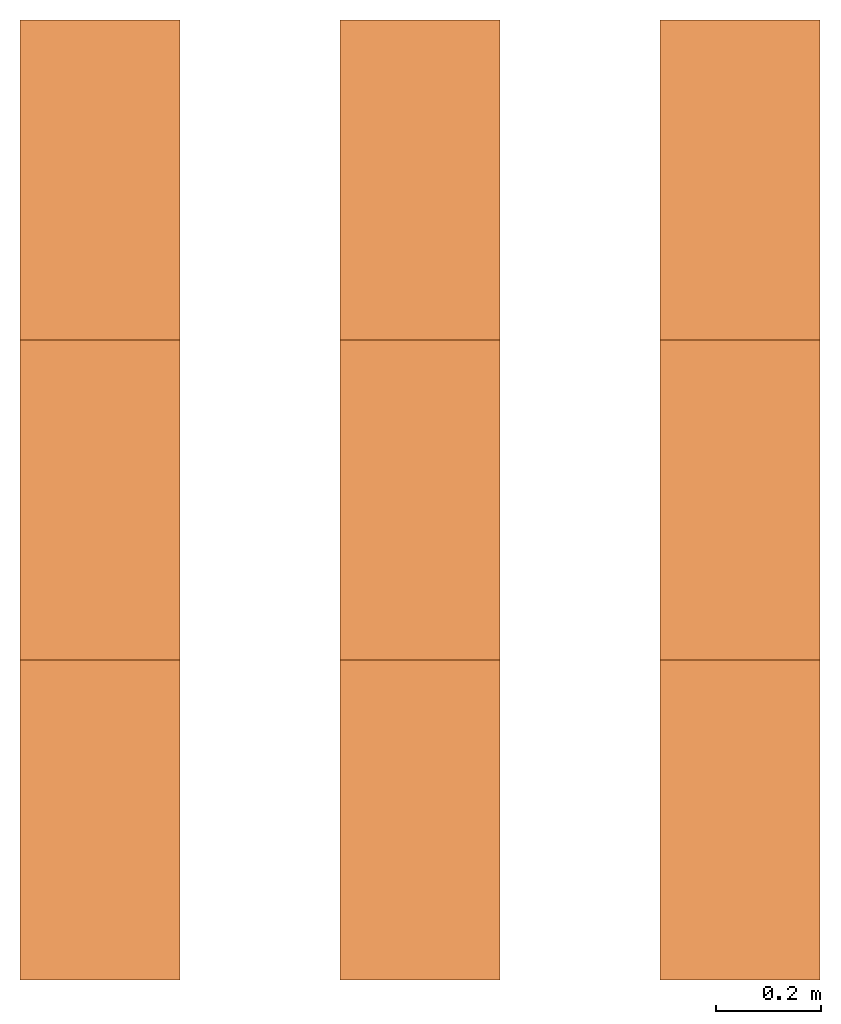
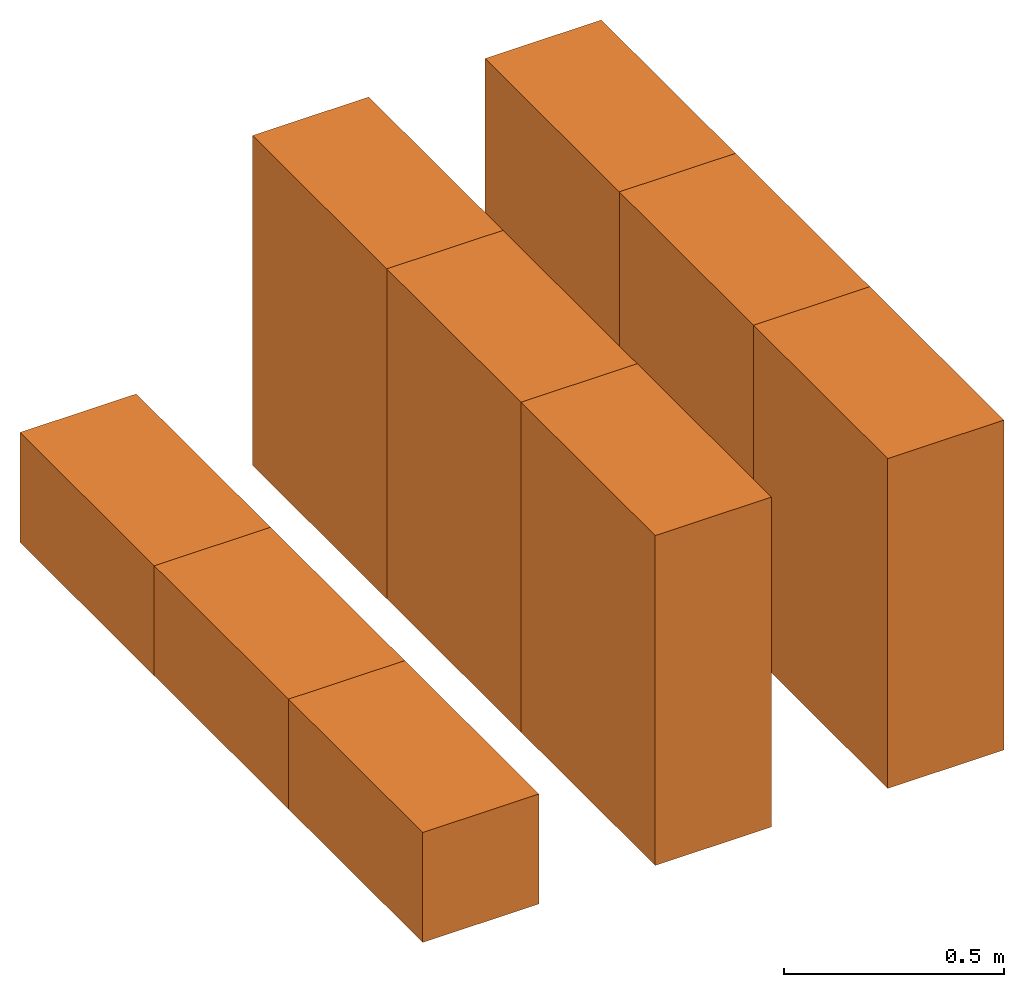
# One storey: 9 proxies.
"""IFC2X3 building model written with IfcOpenShell, lengths in feet."""

from ifc_helpers import new_model, entity, si_unit, converted_unit, derived_unit, direction, frame, frame_2d, origin, origin_2d_with_axis, place, context, subcontext, project, spatial, rectangle, extrude, source, transform, mapped, material, type_object, type_shapes, element, save


model = new_model("IFC2X3")

# Units and contexts
model_context = context("Model", 3, precision=0.0001, world=origin(), true_north=direction((6.12303176911189e-17, 1.0)))
body_context = subcontext(model_context, "Body", "Model", "MODEL_VIEW")
ifc_project = project(units=[converted_unit("LENGTHUNIT", "FOOT", entity("IfcRatioMeasure", 0.3048), si_unit("LENGTHUNIT", "METRE"), dimensions=[1, 0, 0, 0, 0, 0, 0]), converted_unit("AREAUNIT", "SQUARE FOOT", entity("IfcRatioMeasure", 0.09290304), si_unit("AREAUNIT", "SQUARE_METRE"), dimensions=[2, 0, 0, 0, 0, 0, 0]), converted_unit("VOLUMEUNIT", "CUBIC FOOT", entity("IfcRatioMeasure", 0.028316846592), si_unit("VOLUMEUNIT", "CUBIC_METRE"), dimensions=[3, 0, 0, 0, 0, 0, 0]), converted_unit("PLANEANGLEUNIT", "DEGREE", entity("IfcRatioMeasure", 0.0174532925199433), si_unit("PLANEANGLEUNIT", "RADIAN"), dimensions=[0, 0, 0, 0, 0, 0, 0]), si_unit("MASSUNIT", "GRAM", prefix="KILO"), derived_unit("MASSDENSITYUNIT", [(si_unit("MASSUNIT", "GRAM", prefix="KILO"), 1), (si_unit("LENGTHUNIT", "METRE"), -3)]), derived_unit("MOMENTOFINERTIAUNIT", [(si_unit("LENGTHUNIT", "METRE"), 4)]), si_unit("TIMEUNIT", "SECOND"), si_unit("FREQUENCYUNIT", "HERTZ"), si_unit("THERMODYNAMICTEMPERATUREUNIT", "DEGREE_CELSIUS"), derived_unit("THERMALTRANSMITTANCEUNIT", [(si_unit("MASSUNIT", "GRAM", prefix="KILO"), 1), (si_unit("THERMODYNAMICTEMPERATUREUNIT", "KELVIN"), -1), (si_unit("TIMEUNIT", "SECOND"), -3)]), derived_unit("VOLUMETRICFLOWRATEUNIT", [(si_unit("LENGTHUNIT", "METRE"), 3), (si_unit("TIMEUNIT", "SECOND"), -1)]), si_unit("ELECTRICCURRENTUNIT", "AMPERE"), si_unit("ELECTRICVOLTAGEUNIT", "VOLT"), si_unit("POWERUNIT", "WATT"), si_unit("FORCEUNIT", "NEWTON"), si_unit("ILLUMINANCEUNIT", "LUX"), si_unit("LUMINOUSFLUXUNIT", "LUMEN"), si_unit("LUMINOUSINTENSITYUNIT", "CANDELA"), derived_unit("USERDEFINED", [(si_unit("MASSUNIT", "GRAM", prefix="KILO"), -1), (si_unit("LENGTHUNIT", "METRE"), -2), (si_unit("TIMEUNIT", "SECOND"), 3), (si_unit("LUMINOUSFLUXUNIT", "LUMEN"), 1)]), derived_unit("LINEARVELOCITYUNIT", [(si_unit("LENGTHUNIT", "METRE"), 1), (si_unit("TIMEUNIT", "SECOND"), -1)]), si_unit("PRESSUREUNIT", "PASCAL"), derived_unit("USERDEFINED", [(si_unit("LENGTHUNIT", "METRE"), -2), (si_unit("MASSUNIT", "GRAM", prefix="KILO"), 1), (si_unit("TIMEUNIT", "SECOND"), -2)]), derived_unit("LINEARFORCEUNIT", [(si_unit("MASSUNIT", "GRAM", prefix="KILO"), 1), (si_unit("LENGTHUNIT", "METRE"), 1), (si_unit("TIMEUNIT", "SECOND"), -2), (si_unit("LENGTHUNIT", "METRE"), -1)]), derived_unit("PLANARFORCEUNIT", [(si_unit("MASSUNIT", "GRAM", prefix="KILO"), 1), (si_unit("LENGTHUNIT", "METRE"), 1), (si_unit("TIMEUNIT", "SECOND"), -2), (si_unit("LENGTHUNIT", "METRE"), -2)])], contexts=[model_context])

# Site, building, storey
site_placement = place(None, origin())
site = spatial("IfcSite", under=ifc_project, at=site_placement, CompositionType="ELEMENT")
building_placement = place(site_placement, origin())
building = spatial("IfcBuilding", under=site, at=building_placement, CompositionType="ELEMENT")
storey_placement = place(building_placement, origin())
storey = spatial("IfcBuildingStorey", under=building, at=storey_placement, Name="Level 1", CompositionType="ELEMENT", Elevation=0.0)

# Proxies
ifc_material = material()
building_element_proxy_type_1 = type_object("IfcBuildingElementProxyType", PredefinedType="NOTDEFINED", material=ifc_material)
shared_shape_1 = source(origin(), body_context, "Body", "SweptSolid", [
    extrude(rectangle(XDim=2.0, YDim=1.0, at=frame_2d((0.0, 1.11022302462516e-16), x_axis=(1.0, 0.0))), frame((0.500000000000003, 1.0, 0.0), z_axis=(0.0, 0.0, 1.0), x_axis=(0.0, 1.0, 0.0)), (0.0, 0.0, 1.0), 3.0),
])
type_shapes(building_element_proxy_type_1, [shared_shape_1])
proxy_1_placement = place(storey_placement, origin())
element("IfcBuildingElementProxy", 1, at=proxy_1_placement, inside=storey, type_object=building_element_proxy_type_1, material=ifc_material, context=body_context, shape_type="MappedRepresentation", body=[
    mapped(shared_shape_1, transform((0.0, 0.0, 0.0), scale=1.0)),
])
building_element_proxy_type_2 = type_object("IfcBuildingElementProxyType", Name="IPF1:IPF", PredefinedType="NOTDEFINED", material=ifc_material)
shared_shape_2 = source(origin(), body_context, "Body", "SweptSolid", [
    extrude(rectangle(XDim=2.0, YDim=1.0, at=origin_2d_with_axis()), frame((0.500000000000006, 3.0, 0.0), z_axis=(0.0, 0.0, 1.0), x_axis=(0.0, 1.0, 0.0)), (0.0, 0.0, 1.0), 3.0),
])
type_shapes(building_element_proxy_type_2, [shared_shape_2])
proxy_2_placement = place(storey_placement, origin())
element("IfcBuildingElementProxy", 2, at=proxy_2_placement, inside=storey, type_object=building_element_proxy_type_2, material=ifc_material, Name="IPF1", ObjectType="IPF1:IPF", context=body_context, shape_type="MappedRepresentation", body=[
    mapped(shared_shape_2, transform((0.0, 0.0, 0.0), scale=1.0)),
])
building_element_proxy_type_3 = type_object("IfcBuildingElementProxyType", Name="IPF2:IPF", PredefinedType="NOTDEFINED", material=ifc_material)
shared_shape_3 = source(origin(), body_context, "Body", "SweptSolid", [
    extrude(rectangle(XDim=2.0, YDim=1.0, at=origin_2d_with_axis()), frame((0.50000000000001, 5.0, 0.0), z_axis=(0.0, 0.0, 1.0), x_axis=(0.0, 1.0, 0.0)), (0.0, 0.0, 1.0), 3.0),
])
type_shapes(building_element_proxy_type_3, [shared_shape_3])
proxy_3_placement = place(storey_placement, origin())
element("IfcBuildingElementProxy", 3, at=proxy_3_placement, inside=storey, type_object=building_element_proxy_type_3, material=ifc_material, Name="IPF2", ObjectType="IPF2:IPF", context=body_context, shape_type="MappedRepresentation", body=[
    mapped(shared_shape_3, transform((0.0, 0.0, 0.0), scale=1.0)),
])
building_element_proxy_type_4 = type_object("IfcBuildingElementProxyType", Name="IPF3:IPF", PredefinedType="NOTDEFINED", material=ifc_material)
shared_shape_4 = source(origin(), body_context, "Body", "SweptSolid", [
    extrude(rectangle(XDim=2.0, YDim=1.0, at=origin_2d_with_axis()), frame((-1.5, 1.0, 0.0), z_axis=(0.0, 0.0, 1.0), x_axis=(0.0, 1.0, 0.0)), (0.0, 0.0, 1.0), 3.0),
])
type_shapes(building_element_proxy_type_4, [shared_shape_4])
proxy_4_placement = place(storey_placement, origin())
element("IfcBuildingElementProxy", 4, at=proxy_4_placement, inside=storey, type_object=building_element_proxy_type_4, material=ifc_material, Name="IPF3", ObjectType="IPF3:IPF", context=body_context, shape_type="MappedRepresentation", body=[
    mapped(shared_shape_4, transform((0.0, 0.0, 0.0), scale=1.0)),
])
building_element_proxy_type_5 = type_object("IfcBuildingElementProxyType", Name="IPF4:IPF", PredefinedType="NOTDEFINED", material=ifc_material)
shared_shape_5 = source(origin(), body_context, "Body", "SweptSolid", [
    extrude(rectangle(XDim=2.0, YDim=1.0, at=frame_2d((2.22044604925031e-16, 0.0), x_axis=(1.0, 0.0))), frame((-1.49999999999999, 3.0, 0.0), z_axis=(0.0, 0.0, 1.0), x_axis=(0.0, 1.0, 0.0)), (0.0, 0.0, 1.0), 3.0),
])
type_shapes(building_element_proxy_type_5, [shared_shape_5])
proxy_5_placement = place(storey_placement, origin())
element("IfcBuildingElementProxy", 5, at=proxy_5_placement, inside=storey, type_object=building_element_proxy_type_5, material=ifc_material, Name="IPF4", ObjectType="IPF4:IPF", context=body_context, shape_type="MappedRepresentation", body=[
    mapped(shared_shape_5, transform((0.0, 0.0, 0.0), scale=1.0)),
])
building_element_proxy_type_6 = type_object("IfcBuildingElementProxyType", Name="IPF5:IPF", PredefinedType="NOTDEFINED", material=ifc_material)
shared_shape_6 = source(origin(), body_context, "Body", "SweptSolid", [
    extrude(rectangle(XDim=2.0, YDim=1.0, at=origin_2d_with_axis()), frame((-1.49999999999999, 5.0, 0.0), z_axis=(0.0, 0.0, 1.0), x_axis=(0.0, 1.0, 0.0)), (0.0, 0.0, 1.0), 3.0),
])
type_shapes(building_element_proxy_type_6, [shared_shape_6])
proxy_6_placement = place(storey_placement, origin())
element("IfcBuildingElementProxy", 6, at=proxy_6_placement, inside=storey, type_object=building_element_proxy_type_6, material=ifc_material, Name="IPF5", ObjectType="IPF5:IPF", context=body_context, shape_type="MappedRepresentation", body=[
    mapped(shared_shape_6, transform((0.0, 0.0, 0.0), scale=1.0)),
])
building_element_proxy_type_7 = type_object("IfcBuildingElementProxyType", Name="IPF6:IPF", PredefinedType="NOTDEFINED", material=ifc_material)
shared_shape_7 = source(origin(), body_context, "Body", "SweptSolid", [
    extrude(rectangle(XDim=2.0, YDim=1.0, at=frame_2d((-2.22044604925031e-16, 0.0), x_axis=(1.0, 0.0))), frame((-3.5, 1.0, 0.0), z_axis=(0.0, 0.0, 1.0), x_axis=(0.0, 1.0, 0.0)), (0.0, 0.0, 1.0), 1.0),
])
type_shapes(building_element_proxy_type_7, [shared_shape_7])
proxy_7_placement = place(storey_placement, origin())
element("IfcBuildingElementProxy", 7, at=proxy_7_placement, inside=storey, type_object=building_element_proxy_type_7, material=ifc_material, Name="IPF6", ObjectType="IPF6:IPF", context=body_context, shape_type="MappedRepresentation", body=[
    mapped(shared_shape_7, transform((0.0, 0.0, 0.0), scale=1.0)),
])
building_element_proxy_type_8 = type_object("IfcBuildingElementProxyType", Name="IPF7:IPF", PredefinedType="NOTDEFINED", material=ifc_material)
shared_shape_8 = source(origin(), body_context, "Body", "SweptSolid", [
    extrude(rectangle(XDim=2.0, YDim=1.0, at=frame_2d((2.22044604925031e-16, 0.0), x_axis=(1.0, 0.0))), frame((-3.49999999999999, 3.0, 0.0), z_axis=(0.0, 0.0, 1.0), x_axis=(0.0, 1.0, 0.0)), (0.0, 0.0, 1.0), 1.0),
])
type_shapes(building_element_proxy_type_8, [shared_shape_8])
proxy_8_placement = place(storey_placement, origin())
element("IfcBuildingElementProxy", 8, at=proxy_8_placement, inside=storey, type_object=building_element_proxy_type_8, material=ifc_material, Name="IPF7", ObjectType="IPF7:IPF", context=body_context, shape_type="MappedRepresentation", body=[
    mapped(shared_shape_8, transform((0.0, 0.0, 0.0), scale=1.0)),
])
building_element_proxy_type_9 = type_object("IfcBuildingElementProxyType", Name="IPF8:IPF", PredefinedType="NOTDEFINED", material=ifc_material)
shared_shape_9 = source(origin(), body_context, "Body", "SweptSolid", [
    extrude(rectangle(XDim=2.0, YDim=1.0, at=origin_2d_with_axis()), frame((-3.49999999999999, 5.0, 0.0), z_axis=(0.0, 0.0, 1.0), x_axis=(0.0, 1.0, 0.0)), (0.0, 0.0, 1.0), 1.0),
])
type_shapes(building_element_proxy_type_9, [shared_shape_9])
proxy_9_placement = place(storey_placement, origin())
element("IfcBuildingElementProxy", 9, at=proxy_9_placement, inside=storey, type_object=building_element_proxy_type_9, material=ifc_material, Name="IPF8", ObjectType="IPF8:IPF", context=body_context, shape_type="MappedRepresentation", body=[
    mapped(shared_shape_9, transform((0.0, 0.0, 0.0), scale=1.0)),
])

save(model, "model.ifc")
